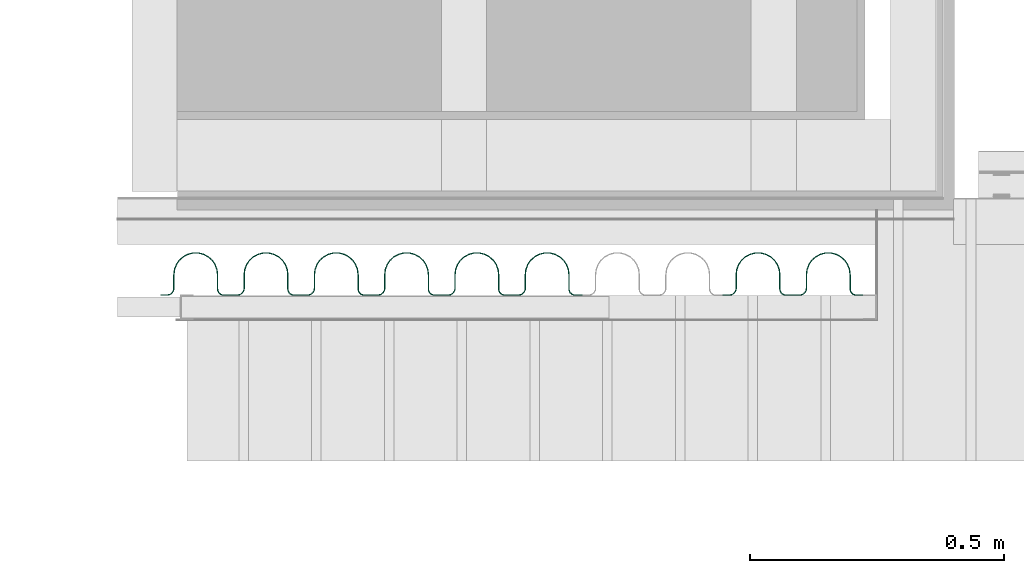
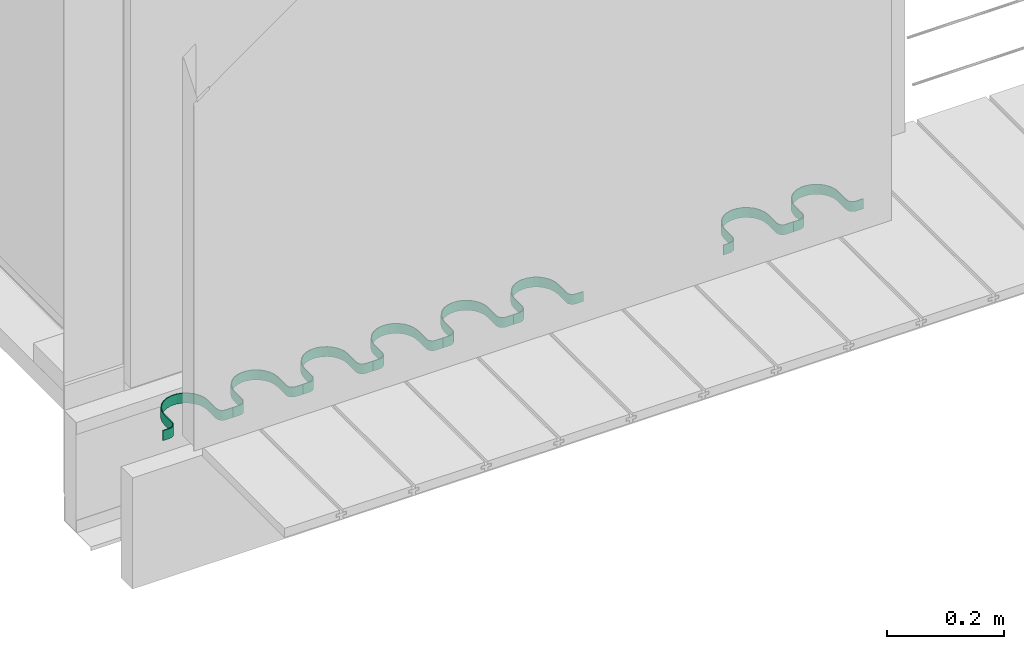
# One storey, part 27 of 33: 8 valves.
"""IFC4 building model written with IfcOpenShell, lengths in feet."""

from ifc_helpers import new_model, entity, si_unit, converted_unit, derived_unit, direction, frame, frame_2d, origin, place, context, subcontext, project, spatial, polyline, circle_curve, parameter, trimmed, segment, composite_curve, outline, extrude, source, transform, mapped, material, type_object, type_shapes, element, save


model = new_model("IFC4")

# Units and contexts
model_context = context("Model", 3, precision=0.0001, world=origin(), true_north=direction((6.12303176911189e-17, 1.0)))
body_context = subcontext(model_context, "Body", "Model", "MODEL_VIEW")
ifc_project = project(units=[converted_unit("LENGTHUNIT", "FOOT", entity("IfcRatioMeasure", 0.3048), si_unit("LENGTHUNIT", "METRE"), dimensions=[1, 0, 0, 0, 0, 0, 0]), converted_unit("AREAUNIT", "SQUARE FOOT", entity("IfcRatioMeasure", 0.09290304), si_unit("AREAUNIT", "SQUARE_METRE"), dimensions=[2, 0, 0, 0, 0, 0, 0]), converted_unit("VOLUMEUNIT", "CUBIC FOOT", entity("IfcRatioMeasure", 0.028316846592), si_unit("VOLUMEUNIT", "CUBIC_METRE"), dimensions=[3, 0, 0, 0, 0, 0, 0]), converted_unit("PLANEANGLEUNIT", "DEGREE", entity("IfcRatioMeasure", 0.0174532925199433), si_unit("PLANEANGLEUNIT", "RADIAN"), dimensions=[0, 0, 0, 0, 0, 0, 0]), si_unit("MASSUNIT", "GRAM", prefix="KILO"), derived_unit("MASSDENSITYUNIT", [(si_unit("MASSUNIT", "GRAM", prefix="KILO"), 1), (si_unit("LENGTHUNIT", "METRE"), -3)]), derived_unit("MOMENTOFINERTIAUNIT", [(si_unit("LENGTHUNIT", "METRE"), 4)]), si_unit("TIMEUNIT", "SECOND"), si_unit("FREQUENCYUNIT", "HERTZ"), si_unit("THERMODYNAMICTEMPERATUREUNIT", "DEGREE_CELSIUS"), derived_unit("THERMALTRANSMITTANCEUNIT", [(si_unit("MASSUNIT", "GRAM", prefix="KILO"), 1), (si_unit("THERMODYNAMICTEMPERATUREUNIT", "KELVIN"), -1), (si_unit("TIMEUNIT", "SECOND"), -3)]), derived_unit("VOLUMETRICFLOWRATEUNIT", [(si_unit("LENGTHUNIT", "METRE"), 3), (si_unit("TIMEUNIT", "SECOND"), -1)]), si_unit("ELECTRICCURRENTUNIT", "AMPERE"), si_unit("ELECTRICVOLTAGEUNIT", "VOLT"), si_unit("POWERUNIT", "WATT"), si_unit("FORCEUNIT", "NEWTON"), si_unit("ILLUMINANCEUNIT", "LUX"), si_unit("LUMINOUSFLUXUNIT", "LUMEN"), si_unit("LUMINOUSINTENSITYUNIT", "CANDELA"), derived_unit("USERDEFINED", [(si_unit("MASSUNIT", "GRAM", prefix="KILO"), -1), (si_unit("LENGTHUNIT", "METRE"), -2), (si_unit("TIMEUNIT", "SECOND"), 3), (si_unit("LUMINOUSFLUXUNIT", "LUMEN"), 1)]), derived_unit("LINEARVELOCITYUNIT", [(si_unit("LENGTHUNIT", "METRE"), 1), (si_unit("TIMEUNIT", "SECOND"), -1)]), si_unit("PRESSUREUNIT", "PASCAL"), derived_unit("USERDEFINED", [(si_unit("LENGTHUNIT", "METRE"), -2), (si_unit("MASSUNIT", "GRAM", prefix="KILO"), 1), (si_unit("TIMEUNIT", "SECOND"), -2)]), derived_unit("LINEARFORCEUNIT", [(si_unit("MASSUNIT", "GRAM", prefix="KILO"), 1), (si_unit("LENGTHUNIT", "METRE"), 1), (si_unit("TIMEUNIT", "SECOND"), -2), (si_unit("LENGTHUNIT", "METRE"), -1)]), derived_unit("PLANARFORCEUNIT", [(si_unit("MASSUNIT", "GRAM", prefix="KILO"), 1), (si_unit("LENGTHUNIT", "METRE"), 1), (si_unit("TIMEUNIT", "SECOND"), -2), (si_unit("LENGTHUNIT", "METRE"), -2)])], contexts=[model_context])

# Site, building, storey
site_placement = place(None, origin())
site = spatial("IfcSite", under=ifc_project, at=site_placement, CompositionType="ELEMENT")
building_placement = place(site_placement, origin())
building = spatial("IfcBuilding", under=site, at=building_placement, CompositionType="ELEMENT")
storey_placement = place(building_placement, frame((0.0, 0.0, 10.0)))
storey = spatial("IfcBuildingStorey", under=building, at=storey_placement, Name="2ND FLOOR", CompositionType="ELEMENT", Elevation=10.0000000000002)

# Valves
ifc_material = material(Name="GALV. U BRACKET AT GALV. PIPE", Category="Materials")
valve_type_1 = type_object("IfcValveType", Name="U BRACKET2:U BRACKET", PredefinedType="NOTDEFINED", material=ifc_material)
shared_shape_1 = source(origin(), body_context, "Body", "SweptSolid", [
    extrude(outline(composite_curve([segment(polyline([(0.0407648216664178, -0.226295029472567), (0.0459731549997509, -0.226295029472567)]), True, "CONTINUOUS"), segment(polyline([(0.0459731549997509, -0.226295029472567), (0.0459731549997509, -0.184628362805825)]), True, "CONTINUOUS"), segment(trimmed(circle_curve(frame_2d((-0.000901845000249146, -0.184628362805825), x_axis=(0.0, 1.0)), 0.046875), [parameter(270.0)], [parameter(2.03555499613665e-13)], True, "PARAMETER"), True, "CONTINUOUS"), segment(polyline([(-0.000901845000249146, -0.137753362805825), (-0.0884402983327055, -0.137753362805825)]), True, "CONTINUOUS"), segment(trimmed(circle_curve(frame_2d((-0.0884402983327037, 0.000651041666515084), x_axis=(0.0, 1.0)), 0.138404404472415), [parameter(2.03555499613665e-13)], [parameter(180.0)], True, "PARAMETER"), False, "CONTINUOUS"), segment(polyline([(-0.0884402983327037, 0.139055446138855), (0.00430648833316294, 0.139055446138855)]), True, "CONTINUOUS"), segment(trimmed(circle_curve(frame_2d((0.00430648833316294, 0.180722112805597), x_axis=(0.0, 1.0)), 0.0416666666666667), [parameter(180.0)], [parameter(270.0)], True, "PARAMETER"), True, "CONTINUOUS"), segment(polyline([(0.0459731549998299, 0.180722112805597), (0.0459731549998308, 0.227597112805597)]), True, "CONTINUOUS"), segment(polyline([(0.0459731549998308, 0.227597112805597), (0.0407648216664969, 0.227597112805597)]), True, "CONTINUOUS"), segment(polyline([(0.0407648216664969, 0.227597112805597), (0.0407648216664969, 0.180722112805597)]), True, "CONTINUOUS"), segment(trimmed(circle_curve(frame_2d((0.00430648833316294, 0.180722112805597), x_axis=(0.0, 1.0)), 0.0364583333333333), [parameter(180.0)], [parameter(270.0)], True, "PARAMETER"), False, "CONTINUOUS"), segment(polyline([(0.00430648833316294, 0.14426377947234), (-0.0884402983327028, 0.14426377947234)]), True, "CONTINUOUS"), segment(trimmed(circle_curve(frame_2d((-0.0884402983327037, 0.000651041666515084), x_axis=(0.0, 1.0)), 0.143612737805749), [parameter(360.0)], [parameter(180.0)], True, "PARAMETER"), True, "CONTINUOUS"), segment(polyline([(-0.0884402983327055, -0.142961696139309), (-0.000901845000249146, -0.142961696139309)]), True, "CONTINUOUS"), segment(trimmed(circle_curve(frame_2d((-0.000901845000249146, -0.184628362805825), x_axis=(0.0, 1.0)), 0.0416666666666667), [parameter(270.0)], [parameter(2.03555499613665e-13)], True, "PARAMETER"), False, "CONTINUOUS"), segment(polyline([(0.0407648216664178, -0.184628362805825), (0.0407648216664178, -0.226295029472567)]), True, "CONTINUOUS")], self_intersect=False)), frame((0.226295029472567, 0.0512069877948296, 0.0), z_axis=(0.0, 0.0, 1.0), x_axis=(0.0, -1.0, 0.0)), (0.0, 0.0, 1.0), 0.0683255255426953),
])
type_shapes(valve_type_1, [shared_shape_1])
valve_1_placement = place(storey_placement, frame((1490.85644733877, 4.11092510371606, 0.757393194068699)))
element("IfcValve", 1, at=valve_1_placement, inside=storey, type_object=valve_type_1, material=ifc_material, Name="U BRACKET2:U BRACKET", ObjectType="U BRACKET2:U BRACKET", PredefinedType="NOTDEFINED", context=body_context, shape_type="MappedRepresentation", body=[
    mapped(shared_shape_1, transform((0.0, 0.0, 0.0), scale=1.0)),
])
valve_type_2 = type_object("IfcValveType", Name="U BRACKET3:U BRACKET", PredefinedType="NOTDEFINED", material=ifc_material)
shared_shape_2 = source(origin(), body_context, "Body", "SweptSolid", [
    extrude(outline(composite_curve([segment(polyline([(0.0407648216664178, -0.226295029472567), (0.0459731549997509, -0.226295029472567)]), True, "CONTINUOUS"), segment(polyline([(0.0459731549997509, -0.226295029472567), (0.0459731549997509, -0.184628362805825)]), True, "CONTINUOUS"), segment(trimmed(circle_curve(frame_2d((-0.000901845000249146, -0.184628362805825), x_axis=(0.0, 1.0)), 0.046875), [parameter(270.0)], [parameter(2.03555499613665e-13)], True, "PARAMETER"), True, "CONTINUOUS"), segment(polyline([(-0.000901845000249146, -0.137753362805825), (-0.0884402983327046, -0.137753362805825)]), True, "CONTINUOUS"), segment(trimmed(circle_curve(frame_2d((-0.0884402983327037, 0.000651041666515084), x_axis=(0.0, 1.0)), 0.138404404472415), [parameter(2.03555499613665e-13)], [parameter(180.0)], True, "PARAMETER"), False, "CONTINUOUS"), segment(polyline([(-0.0884402983327037, 0.139055446138855), (0.00430648833316294, 0.139055446138855)]), True, "CONTINUOUS"), segment(trimmed(circle_curve(frame_2d((0.00430648833316294, 0.180722112805597), x_axis=(0.0, 1.0)), 0.0416666666666667), [parameter(180.0)], [parameter(270.0)], True, "PARAMETER"), True, "CONTINUOUS"), segment(polyline([(0.0459731549998299, 0.180722112805597), (0.0459731549998308, 0.227597112805597)]), True, "CONTINUOUS"), segment(polyline([(0.0459731549998308, 0.227597112805597), (0.0407648216664969, 0.227597112805597)]), True, "CONTINUOUS"), segment(polyline([(0.0407648216664969, 0.227597112805597), (0.0407648216664969, 0.180722112805597)]), True, "CONTINUOUS"), segment(trimmed(circle_curve(frame_2d((0.00430648833316294, 0.180722112805597), x_axis=(0.0, 1.0)), 0.0364583333333333), [parameter(180.0)], [parameter(270.0)], True, "PARAMETER"), False, "CONTINUOUS"), segment(polyline([(0.00430648833316294, 0.14426377947234), (-0.0884402983327028, 0.14426377947234)]), True, "CONTINUOUS"), segment(trimmed(circle_curve(frame_2d((-0.0884402983327037, 0.000651041666515084), x_axis=(0.0, 1.0)), 0.143612737805749), [parameter(360.0)], [parameter(180.0)], True, "PARAMETER"), True, "CONTINUOUS"), segment(polyline([(-0.0884402983327055, -0.142961696139309), (-0.000901845000249146, -0.142961696139309)]), True, "CONTINUOUS"), segment(trimmed(circle_curve(frame_2d((-0.000901845000249146, -0.184628362805825), x_axis=(0.0, 1.0)), 0.0416666666666667), [parameter(270.0)], [parameter(2.03555499613665e-13)], True, "PARAMETER"), False, "CONTINUOUS"), segment(polyline([(0.0407648216664178, -0.184628362805825), (0.0407648216664178, -0.226295029472567)]), True, "CONTINUOUS")], self_intersect=False)), frame((0.226295029472567, 0.0512069877948296, 0.0), z_axis=(0.0, 0.0, 1.0), x_axis=(0.0, -1.0, 0.0)), (0.0, 0.0, 1.0), 0.0683255255426953),
])
type_shapes(valve_type_2, [shared_shape_2])
valve_2_placement = place(storey_placement, frame((1491.31033948105, 4.11092510371606, 0.757393194068703)))
element("IfcValve", 2, at=valve_2_placement, inside=storey, type_object=valve_type_2, material=ifc_material, Name="U BRACKET3:U BRACKET", ObjectType="U BRACKET3:U BRACKET", PredefinedType="NOTDEFINED", context=body_context, shape_type="MappedRepresentation", body=[
    mapped(shared_shape_2, transform((0.0, 0.0, 0.0), scale=1.0)),
])
valve_type_3 = type_object("IfcValveType", Name="U BRACKET9:U BRACKET", PredefinedType="NOTDEFINED", material=ifc_material)
shared_shape_3 = source(origin(), body_context, "Body", "SweptSolid", [
    extrude(outline(composite_curve([segment(polyline([(0.0407648216664178, -0.226295029472567), (0.0459731549997509, -0.226295029472567)]), True, "CONTINUOUS"), segment(polyline([(0.0459731549997509, -0.226295029472567), (0.0459731549997509, -0.184628362805825)]), True, "CONTINUOUS"), segment(trimmed(circle_curve(frame_2d((-0.000901845000249146, -0.184628362805825), x_axis=(0.0, 1.0)), 0.046875), [parameter(270.0)], [parameter(2.03555499613665e-13)], True, "PARAMETER"), True, "CONTINUOUS"), segment(polyline([(-0.000901845000249146, -0.137753362805825), (-0.0884402983327046, -0.137753362805825)]), True, "CONTINUOUS"), segment(trimmed(circle_curve(frame_2d((-0.0884402983327037, 0.000651041666515084), x_axis=(0.0, 1.0)), 0.138404404472415), [parameter(2.03555499613665e-13)], [parameter(180.0)], True, "PARAMETER"), False, "CONTINUOUS"), segment(polyline([(-0.0884402983327037, 0.139055446138855), (0.00430648833316294, 0.139055446138855)]), True, "CONTINUOUS"), segment(trimmed(circle_curve(frame_2d((0.00430648833316294, 0.180722112805597), x_axis=(0.0, 1.0)), 0.0416666666666667), [parameter(180.0)], [parameter(270.0)], True, "PARAMETER"), True, "CONTINUOUS"), segment(polyline([(0.0459731549998299, 0.180722112805597), (0.0459731549998308, 0.227597112805597)]), True, "CONTINUOUS"), segment(polyline([(0.0459731549998308, 0.227597112805597), (0.0407648216664969, 0.227597112805597)]), True, "CONTINUOUS"), segment(polyline([(0.0407648216664969, 0.227597112805597), (0.0407648216664969, 0.180722112805597)]), True, "CONTINUOUS"), segment(trimmed(circle_curve(frame_2d((0.00430648833316294, 0.180722112805597), x_axis=(0.0, 1.0)), 0.0364583333333333), [parameter(180.0)], [parameter(270.0)], True, "PARAMETER"), False, "CONTINUOUS"), segment(polyline([(0.00430648833316294, 0.14426377947234), (-0.0884402983327028, 0.14426377947234)]), True, "CONTINUOUS"), segment(trimmed(circle_curve(frame_2d((-0.0884402983327037, 0.000651041666515084), x_axis=(0.0, 1.0)), 0.143612737805749), [parameter(360.0)], [parameter(180.0)], True, "PARAMETER"), True, "CONTINUOUS"), segment(polyline([(-0.0884402983327055, -0.142961696139309), (-0.000901845000249146, -0.142961696139309)]), True, "CONTINUOUS"), segment(trimmed(circle_curve(frame_2d((-0.000901845000249146, -0.184628362805825), x_axis=(0.0, 1.0)), 0.0416666666666667), [parameter(270.0)], [parameter(2.03555499613665e-13)], True, "PARAMETER"), False, "CONTINUOUS"), segment(polyline([(0.0407648216664178, -0.184628362805825), (0.0407648216664178, -0.226295029472567)]), True, "CONTINUOUS")], self_intersect=False)), frame((0.226295029472567, 0.0512069877948296, 0.0), z_axis=(0.0, 0.0, 1.0), x_axis=(0.0, -1.0, 0.0)), (0.0, 0.0, 1.0), 0.0683255255426953),
])
type_shapes(valve_type_3, [shared_shape_3])
valve_3_placement = place(storey_placement, frame((1489.49477091193, 4.11092510371607, 0.757393194068694)))
element("IfcValve", 3, at=valve_3_placement, inside=storey, type_object=valve_type_3, material=ifc_material, Name="U BRACKET9:U BRACKET", ObjectType="U BRACKET9:U BRACKET", PredefinedType="NOTDEFINED", context=body_context, shape_type="MappedRepresentation", body=[
    mapped(shared_shape_3, transform((0.0, 0.0, 0.0), scale=1.0)),
])
valve_type_4 = type_object("IfcValveType", Name="U BRACKET11:U BRACKET", PredefinedType="NOTDEFINED", material=ifc_material)
shared_shape_4 = source(origin(), body_context, "Body", "SweptSolid", [
    extrude(outline(composite_curve([segment(polyline([(0.0407648216664178, -0.226295029472567), (0.0459731549997509, -0.226295029472567)]), True, "CONTINUOUS"), segment(polyline([(0.0459731549997509, -0.226295029472567), (0.0459731549997509, -0.184628362805825)]), True, "CONTINUOUS"), segment(trimmed(circle_curve(frame_2d((-0.000901845000249146, -0.184628362805825), x_axis=(0.0, 1.0)), 0.046875), [parameter(270.0)], [parameter(2.03555499613665e-13)], True, "PARAMETER"), True, "CONTINUOUS"), segment(polyline([(-0.000901845000249146, -0.137753362805825), (-0.0884402983327046, -0.137753362805825)]), True, "CONTINUOUS"), segment(trimmed(circle_curve(frame_2d((-0.0884402983327037, 0.000651041666515084), x_axis=(0.0, 1.0)), 0.138404404472415), [parameter(2.03555499613665e-13)], [parameter(180.0)], True, "PARAMETER"), False, "CONTINUOUS"), segment(polyline([(-0.0884402983327037, 0.139055446138855), (0.00430648833316294, 0.139055446138855)]), True, "CONTINUOUS"), segment(trimmed(circle_curve(frame_2d((0.00430648833316294, 0.180722112805597), x_axis=(0.0, 1.0)), 0.0416666666666667), [parameter(180.0)], [parameter(270.0)], True, "PARAMETER"), True, "CONTINUOUS"), segment(polyline([(0.0459731549998299, 0.180722112805597), (0.0459731549998308, 0.227597112805597)]), True, "CONTINUOUS"), segment(polyline([(0.0459731549998308, 0.227597112805597), (0.0407648216664969, 0.227597112805597)]), True, "CONTINUOUS"), segment(polyline([(0.0407648216664969, 0.227597112805597), (0.0407648216664969, 0.180722112805597)]), True, "CONTINUOUS"), segment(trimmed(circle_curve(frame_2d((0.00430648833316294, 0.180722112805597), x_axis=(0.0, 1.0)), 0.0364583333333333), [parameter(180.0)], [parameter(270.0)], True, "PARAMETER"), False, "CONTINUOUS"), segment(polyline([(0.00430648833316294, 0.14426377947234), (-0.0884402983327028, 0.14426377947234)]), True, "CONTINUOUS"), segment(trimmed(circle_curve(frame_2d((-0.0884402983327037, 0.000651041666515084), x_axis=(0.0, 1.0)), 0.143612737805749), [parameter(360.0)], [parameter(180.0)], True, "PARAMETER"), True, "CONTINUOUS"), segment(polyline([(-0.0884402983327055, -0.142961696139309), (-0.000901845000249146, -0.142961696139309)]), True, "CONTINUOUS"), segment(trimmed(circle_curve(frame_2d((-0.000901845000249146, -0.184628362805825), x_axis=(0.0, 1.0)), 0.0416666666666667), [parameter(270.0)], [parameter(2.03555499613665e-13)], True, "PARAMETER"), False, "CONTINUOUS"), segment(polyline([(0.0407648216664178, -0.184628362805825), (0.0407648216664178, -0.226295029472567)]), True, "CONTINUOUS")], self_intersect=False)), frame((0.226295029472567, 0.0512069877948296, 0.0), z_axis=(0.0, 0.0, 1.0), x_axis=(0.0, -1.0, 0.0)), (0.0, 0.0, 1.0), 0.0683255255426953),
])
type_shapes(valve_type_4, [shared_shape_4])
valve_4_placement = place(storey_placement, frame((1489.04087876966, 4.11092510371607, 0.757393194068692)))
element("IfcValve", 4, at=valve_4_placement, inside=storey, type_object=valve_type_4, material=ifc_material, Name="U BRACKET11:U BRACKET", ObjectType="U BRACKET11:U BRACKET", PredefinedType="NOTDEFINED", context=body_context, shape_type="MappedRepresentation", body=[
    mapped(shared_shape_4, transform((0.0, 0.0, 0.0), scale=1.0)),
])
valve_type_5 = type_object("IfcValveType", Name="U BRACKET13:U BRACKET", PredefinedType="NOTDEFINED", material=ifc_material)
shared_shape_5 = source(origin(), body_context, "Body", "SweptSolid", [
    extrude(outline(composite_curve([segment(polyline([(0.0407648216664178, -0.226295029472567), (0.0459731549997509, -0.226295029472567)]), True, "CONTINUOUS"), segment(polyline([(0.0459731549997509, -0.226295029472567), (0.0459731549997509, -0.184628362805825)]), True, "CONTINUOUS"), segment(trimmed(circle_curve(frame_2d((-0.000901845000249146, -0.184628362805825), x_axis=(0.0, 1.0)), 0.046875), [parameter(270.0)], [parameter(2.03555499613665e-13)], True, "PARAMETER"), True, "CONTINUOUS"), segment(polyline([(-0.000901845000249146, -0.137753362805825), (-0.0884402983327046, -0.137753362805825)]), True, "CONTINUOUS"), segment(trimmed(circle_curve(frame_2d((-0.0884402983327037, 0.000651041666515084), x_axis=(0.0, 1.0)), 0.138404404472415), [parameter(2.03555499613665e-13)], [parameter(180.0)], True, "PARAMETER"), False, "CONTINUOUS"), segment(polyline([(-0.0884402983327037, 0.139055446138855), (0.00430648833316294, 0.139055446138855)]), True, "CONTINUOUS"), segment(trimmed(circle_curve(frame_2d((0.00430648833316294, 0.180722112805597), x_axis=(0.0, 1.0)), 0.0416666666666667), [parameter(180.0)], [parameter(270.0)], True, "PARAMETER"), True, "CONTINUOUS"), segment(polyline([(0.0459731549998299, 0.180722112805597), (0.0459731549998308, 0.227597112805597)]), True, "CONTINUOUS"), segment(polyline([(0.0459731549998308, 0.227597112805597), (0.0407648216664969, 0.227597112805597)]), True, "CONTINUOUS"), segment(polyline([(0.0407648216664969, 0.227597112805597), (0.0407648216664969, 0.180722112805597)]), True, "CONTINUOUS"), segment(trimmed(circle_curve(frame_2d((0.00430648833316294, 0.180722112805597), x_axis=(0.0, 1.0)), 0.0364583333333333), [parameter(180.0)], [parameter(270.0)], True, "PARAMETER"), False, "CONTINUOUS"), segment(polyline([(0.00430648833316294, 0.14426377947234), (-0.0884402983327028, 0.14426377947234)]), True, "CONTINUOUS"), segment(trimmed(circle_curve(frame_2d((-0.0884402983327037, 0.000651041666515084), x_axis=(0.0, 1.0)), 0.143612737805749), [parameter(360.0)], [parameter(180.0)], True, "PARAMETER"), True, "CONTINUOUS"), segment(polyline([(-0.0884402983327055, -0.142961696139309), (-0.000901845000249146, -0.142961696139309)]), True, "CONTINUOUS"), segment(trimmed(circle_curve(frame_2d((-0.000901845000249146, -0.184628362805825), x_axis=(0.0, 1.0)), 0.0416666666666667), [parameter(270.0)], [parameter(2.03555499613665e-13)], True, "PARAMETER"), False, "CONTINUOUS"), segment(polyline([(0.0407648216664178, -0.184628362805825), (0.0407648216664178, -0.226295029472567)]), True, "CONTINUOUS")], self_intersect=False)), frame((0.226295029472567, 0.0512069877948296, 0.0), z_axis=(0.0, 0.0, 1.0), x_axis=(0.0, -1.0, 0.0)), (0.0, 0.0, 1.0), 0.0683255255426953),
])
type_shapes(valve_type_5, [shared_shape_5])
valve_5_placement = place(storey_placement, frame((1488.58698662738, 4.11092510371607, 0.75739319406869)))
element("IfcValve", 5, at=valve_5_placement, inside=storey, type_object=valve_type_5, material=ifc_material, Name="U BRACKET13:U BRACKET", ObjectType="U BRACKET13:U BRACKET", PredefinedType="NOTDEFINED", context=body_context, shape_type="MappedRepresentation", body=[
    mapped(shared_shape_5, transform((0.0, 0.0, 0.0), scale=1.0)),
])
valve_type_6 = type_object("IfcValveType", Name="U BRACKET15:U BRACKET", PredefinedType="NOTDEFINED", material=ifc_material)
shared_shape_6 = source(origin(), body_context, "Body", "SweptSolid", [
    extrude(outline(composite_curve([segment(polyline([(0.0407648216664178, -0.226295029472567), (0.0459731549997509, -0.226295029472567)]), True, "CONTINUOUS"), segment(polyline([(0.0459731549997509, -0.226295029472567), (0.0459731549997509, -0.184628362805825)]), True, "CONTINUOUS"), segment(trimmed(circle_curve(frame_2d((-0.000901845000249146, -0.184628362805825), x_axis=(0.0, 1.0)), 0.046875), [parameter(270.0)], [parameter(2.03555499613665e-13)], True, "PARAMETER"), True, "CONTINUOUS"), segment(polyline([(-0.000901845000249146, -0.137753362805825), (-0.0884402983327046, -0.137753362805825)]), True, "CONTINUOUS"), segment(trimmed(circle_curve(frame_2d((-0.0884402983327037, 0.000651041666515084), x_axis=(0.0, 1.0)), 0.138404404472415), [parameter(2.03555499613665e-13)], [parameter(180.0)], True, "PARAMETER"), False, "CONTINUOUS"), segment(polyline([(-0.0884402983327037, 0.139055446138855), (0.00430648833316294, 0.139055446138855)]), True, "CONTINUOUS"), segment(trimmed(circle_curve(frame_2d((0.00430648833316294, 0.180722112805597), x_axis=(0.0, 1.0)), 0.0416666666666667), [parameter(180.0)], [parameter(270.0)], True, "PARAMETER"), True, "CONTINUOUS"), segment(polyline([(0.0459731549998299, 0.180722112805597), (0.0459731549998308, 0.227597112805597)]), True, "CONTINUOUS"), segment(polyline([(0.0459731549998308, 0.227597112805597), (0.0407648216664969, 0.227597112805597)]), True, "CONTINUOUS"), segment(polyline([(0.0407648216664969, 0.227597112805597), (0.0407648216664969, 0.180722112805597)]), True, "CONTINUOUS"), segment(trimmed(circle_curve(frame_2d((0.00430648833316294, 0.180722112805597), x_axis=(0.0, 1.0)), 0.0364583333333333), [parameter(180.0)], [parameter(270.0)], True, "PARAMETER"), False, "CONTINUOUS"), segment(polyline([(0.00430648833316294, 0.14426377947234), (-0.0884402983327028, 0.14426377947234)]), True, "CONTINUOUS"), segment(trimmed(circle_curve(frame_2d((-0.0884402983327037, 0.000651041666515084), x_axis=(0.0, 1.0)), 0.143612737805749), [parameter(360.0)], [parameter(180.0)], True, "PARAMETER"), True, "CONTINUOUS"), segment(polyline([(-0.0884402983327055, -0.142961696139309), (-0.000901845000249146, -0.142961696139309)]), True, "CONTINUOUS"), segment(trimmed(circle_curve(frame_2d((-0.000901845000249146, -0.184628362805825), x_axis=(0.0, 1.0)), 0.0416666666666667), [parameter(270.0)], [parameter(2.03555499613665e-13)], True, "PARAMETER"), False, "CONTINUOUS"), segment(polyline([(0.0407648216664178, -0.184628362805825), (0.0407648216664178, -0.226295029472567)]), True, "CONTINUOUS")], self_intersect=False)), frame((0.226295029472567, 0.0512069877948296, 0.0), z_axis=(0.0, 0.0, 1.0), x_axis=(0.0, -1.0, 0.0)), (0.0, 0.0, 1.0), 0.0683255255426953),
])
type_shapes(valve_type_6, [shared_shape_6])
valve_6_placement = place(storey_placement, frame((1488.1330944851, 4.11092510371608, 0.757393194068689)))
element("IfcValve", 6, at=valve_6_placement, inside=storey, type_object=valve_type_6, material=ifc_material, Name="U BRACKET15:U BRACKET", ObjectType="U BRACKET15:U BRACKET", PredefinedType="NOTDEFINED", context=body_context, shape_type="MappedRepresentation", body=[
    mapped(shared_shape_6, transform((0.0, 0.0, 0.0), scale=1.0)),
])
valve_type_7 = type_object("IfcValveType", Name="U BRACKET17:U BRACKET", PredefinedType="NOTDEFINED", material=ifc_material)
shared_shape_7 = source(origin(), body_context, "Body", "SweptSolid", [
    extrude(outline(composite_curve([segment(polyline([(0.0407648216664178, -0.226295029472567), (0.0459731549997509, -0.226295029472567)]), True, "CONTINUOUS"), segment(polyline([(0.0459731549997509, -0.226295029472567), (0.0459731549997509, -0.184628362805825)]), True, "CONTINUOUS"), segment(trimmed(circle_curve(frame_2d((-0.000901845000249146, -0.184628362805825), x_axis=(0.0, 1.0)), 0.046875), [parameter(270.0)], [parameter(2.03555499613665e-13)], True, "PARAMETER"), True, "CONTINUOUS"), segment(polyline([(-0.000901845000249146, -0.137753362805825), (-0.0884402983327046, -0.137753362805825)]), True, "CONTINUOUS"), segment(trimmed(circle_curve(frame_2d((-0.0884402983327037, 0.000651041666515084), x_axis=(0.0, 1.0)), 0.138404404472415), [parameter(2.03555499613665e-13)], [parameter(180.0)], True, "PARAMETER"), False, "CONTINUOUS"), segment(polyline([(-0.0884402983327037, 0.139055446138855), (0.00430648833316294, 0.139055446138855)]), True, "CONTINUOUS"), segment(trimmed(circle_curve(frame_2d((0.00430648833316294, 0.180722112805597), x_axis=(0.0, 1.0)), 0.0416666666666667), [parameter(180.0)], [parameter(270.0)], True, "PARAMETER"), True, "CONTINUOUS"), segment(polyline([(0.0459731549998299, 0.180722112805597), (0.0459731549998308, 0.227597112805597)]), True, "CONTINUOUS"), segment(polyline([(0.0459731549998308, 0.227597112805597), (0.0407648216664969, 0.227597112805597)]), True, "CONTINUOUS"), segment(polyline([(0.0407648216664969, 0.227597112805597), (0.0407648216664969, 0.180722112805597)]), True, "CONTINUOUS"), segment(trimmed(circle_curve(frame_2d((0.00430648833316294, 0.180722112805597), x_axis=(0.0, 1.0)), 0.0364583333333333), [parameter(180.0)], [parameter(270.0)], True, "PARAMETER"), False, "CONTINUOUS"), segment(polyline([(0.00430648833316294, 0.14426377947234), (-0.0884402983327028, 0.14426377947234)]), True, "CONTINUOUS"), segment(trimmed(circle_curve(frame_2d((-0.0884402983327037, 0.000651041666515084), x_axis=(0.0, 1.0)), 0.143612737805749), [parameter(360.0)], [parameter(180.0)], True, "PARAMETER"), True, "CONTINUOUS"), segment(polyline([(-0.0884402983327055, -0.142961696139309), (-0.000901845000249146, -0.142961696139309)]), True, "CONTINUOUS"), segment(trimmed(circle_curve(frame_2d((-0.000901845000249146, -0.184628362805825), x_axis=(0.0, 1.0)), 0.0416666666666667), [parameter(270.0)], [parameter(2.03555499613665e-13)], True, "PARAMETER"), False, "CONTINUOUS"), segment(polyline([(0.0407648216664178, -0.184628362805825), (0.0407648216664178, -0.226295029472567)]), True, "CONTINUOUS")], self_intersect=False)), frame((0.226295029472567, 0.0512069877948296, 0.0), z_axis=(0.0, 0.0, 1.0), x_axis=(0.0, -1.0, 0.0)), (0.0, 0.0, 1.0), 0.0683255255426953),
])
type_shapes(valve_type_7, [shared_shape_7])
valve_7_placement = place(storey_placement, frame((1487.67920234282, 4.11092510371608, 0.757393194068687)))
element("IfcValve", 7, at=valve_7_placement, inside=storey, type_object=valve_type_7, material=ifc_material, Name="U BRACKET17:U BRACKET", ObjectType="U BRACKET17:U BRACKET", PredefinedType="NOTDEFINED", context=body_context, shape_type="MappedRepresentation", body=[
    mapped(shared_shape_7, transform((0.0, 0.0, 0.0), scale=1.0)),
])
valve_type_8 = type_object("IfcValveType", Name="U BRACKET19:U BRACKET", PredefinedType="NOTDEFINED", material=ifc_material)
shared_shape_8 = source(origin(), body_context, "Body", "SweptSolid", [
    extrude(outline(composite_curve([segment(polyline([(0.0407648216664178, -0.226295029472567), (0.0459731549997509, -0.226295029472567)]), True, "CONTINUOUS"), segment(polyline([(0.0459731549997509, -0.226295029472567), (0.0459731549997509, -0.184628362805825)]), True, "CONTINUOUS"), segment(trimmed(circle_curve(frame_2d((-0.000901845000249146, -0.184628362805825), x_axis=(0.0, 1.0)), 0.046875), [parameter(270.0)], [parameter(2.03555499613665e-13)], True, "PARAMETER"), True, "CONTINUOUS"), segment(polyline([(-0.000901845000249146, -0.137753362805825), (-0.0884402983327046, -0.137753362805825)]), True, "CONTINUOUS"), segment(trimmed(circle_curve(frame_2d((-0.0884402983327037, 0.000651041666515084), x_axis=(0.0, 1.0)), 0.138404404472415), [parameter(2.03555499613665e-13)], [parameter(180.0)], True, "PARAMETER"), False, "CONTINUOUS"), segment(polyline([(-0.0884402983327037, 0.139055446138855), (0.00430648833316294, 0.139055446138855)]), True, "CONTINUOUS"), segment(trimmed(circle_curve(frame_2d((0.00430648833316294, 0.180722112805597), x_axis=(0.0, 1.0)), 0.0416666666666667), [parameter(180.0)], [parameter(270.0)], True, "PARAMETER"), True, "CONTINUOUS"), segment(polyline([(0.0459731549998299, 0.180722112805597), (0.0459731549998308, 0.227597112805597)]), True, "CONTINUOUS"), segment(polyline([(0.0459731549998308, 0.227597112805597), (0.0407648216664969, 0.227597112805597)]), True, "CONTINUOUS"), segment(polyline([(0.0407648216664969, 0.227597112805597), (0.0407648216664969, 0.180722112805597)]), True, "CONTINUOUS"), segment(trimmed(circle_curve(frame_2d((0.00430648833316294, 0.180722112805597), x_axis=(0.0, 1.0)), 0.0364583333333333), [parameter(180.0)], [parameter(270.0)], True, "PARAMETER"), False, "CONTINUOUS"), segment(polyline([(0.00430648833316294, 0.14426377947234), (-0.0884402983327028, 0.14426377947234)]), True, "CONTINUOUS"), segment(trimmed(circle_curve(frame_2d((-0.0884402983327037, 0.000651041666515084), x_axis=(0.0, 1.0)), 0.143612737805749), [parameter(360.0)], [parameter(180.0)], True, "PARAMETER"), True, "CONTINUOUS"), segment(polyline([(-0.0884402983327055, -0.142961696139309), (-0.000901845000249146, -0.142961696139309)]), True, "CONTINUOUS"), segment(trimmed(circle_curve(frame_2d((-0.000901845000249146, -0.184628362805825), x_axis=(0.0, 1.0)), 0.0416666666666667), [parameter(270.0)], [parameter(2.03555499613665e-13)], True, "PARAMETER"), False, "CONTINUOUS"), segment(polyline([(0.0407648216664178, -0.184628362805825), (0.0407648216664178, -0.226295029472567)]), True, "CONTINUOUS")], self_intersect=False)), frame((0.226295029472567, 0.0512069877948296, 0.0), z_axis=(0.0, 0.0, 1.0), x_axis=(0.0, -1.0, 0.0)), (0.0, 0.0, 1.0), 0.0683255255426953),
])
type_shapes(valve_type_8, [shared_shape_8])
valve_8_placement = place(storey_placement, frame((1487.22531020054, 4.11092510371608, 0.757393194068685)))
element("IfcValve", 8, at=valve_8_placement, inside=storey, type_object=valve_type_8, material=ifc_material, Name="U BRACKET19:U BRACKET", ObjectType="U BRACKET19:U BRACKET", PredefinedType="NOTDEFINED", context=body_context, shape_type="MappedRepresentation", body=[
    mapped(shared_shape_8, transform((0.0, 0.0, 0.0), scale=1.0)),
])

save(model, "model.ifc")
